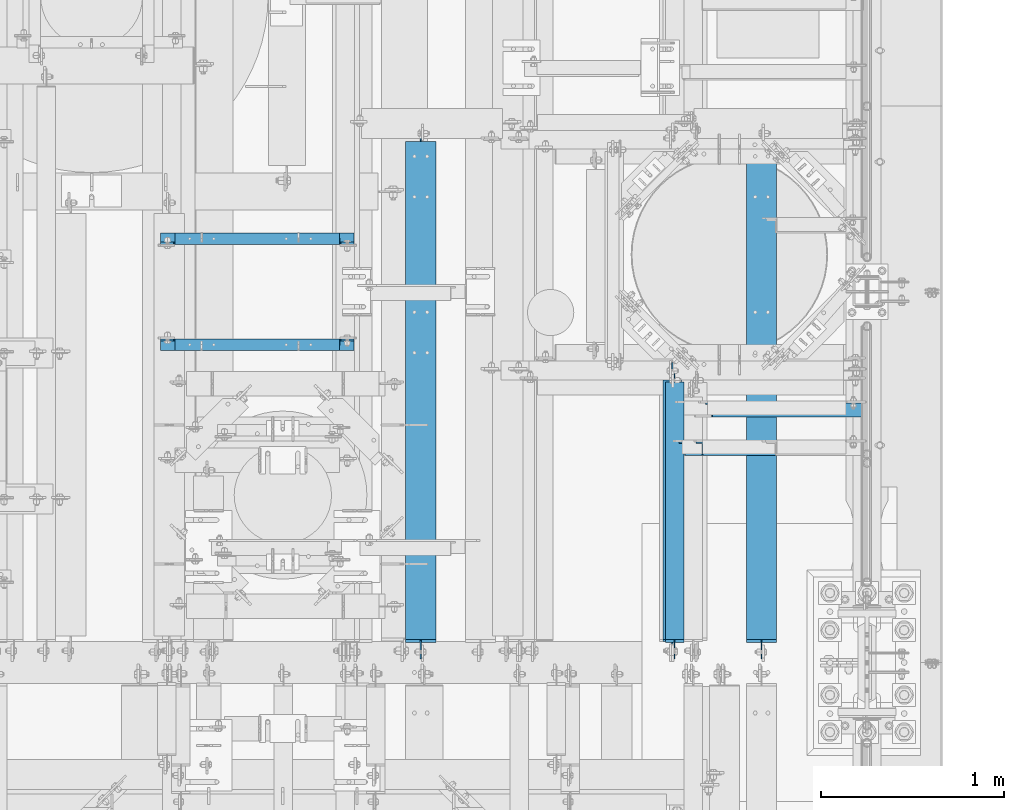
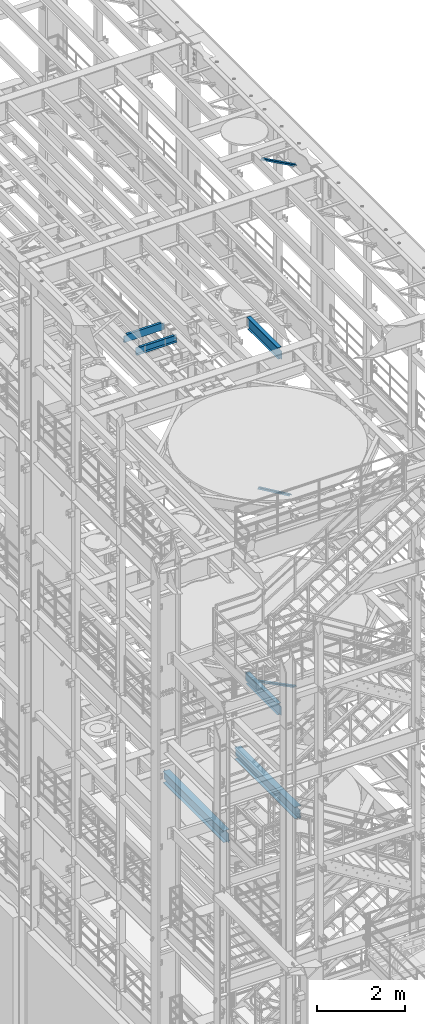
# One storey, part 1027 of 1876: 6 beams, 3 members, 9 elements without a shape of their own.
"""IFC2X3 building model written with IfcOpenShell, lengths in millimetres."""

import ifcopenshell
import ifcopenshell.guid

model = None  # the IFC model being written
_history = None  # IfcOwnerHistory: only IFC2X3 demands one
_inside = {}  # id of a spatial element -> (the spatial element, [elements in it])
_under = {}  # id of a project, library or spatial element -> (it, [spatial elements below it])
_declared = {}  # id of a project -> (the project, [libraries it declares])
_typed = {}  # id of a type object -> (the type object, [elements of that type])
_made_of = {}  # id of a material, layer set ... -> (it, [elements and type objects made of it])


def new_model(schema):
    """Start an empty IFC model of exactly this schema.

    Asked for "IFC4X3", IfcOpenShell would pick the latest addendum, in which some entities
    have other attributes; the version numbers below select the first issue.
    IFC2X3 requires an IfcOwnerHistory on every rooted entity: one is made here for all.
    """
    global model, _history
    if schema == "IFC4X3":
        model = ifcopenshell.file(schema_version=(4, 3, 0, 0))
    else:
        model = ifcopenshell.file(schema=schema)
    _inside.clear()
    _under.clear()
    _declared.clear()
    _typed.clear()
    _made_of.clear()
    _history = None
    if model.schema == "IFC2X3":
        org = make("IfcOrganization", Name="unknown")
        user = make(
            "IfcPersonAndOrganization",
            ThePerson=make("IfcPerson", FamilyName="unknown"),
            TheOrganization=org,
        )
        app = make(
            "IfcApplication",
            ApplicationDeveloper=org,
            Version="unknown",
            ApplicationFullName="unknown",
            ApplicationIdentifier="unknown",
        )
        _history = make(
            "IfcOwnerHistory",
            OwningUser=user,
            OwningApplication=app,
            ChangeAction="ADDED",
            CreationDate=0,
        )
    return model


def make(cls, **values):
    """One entity of the class cls with the attributes given. An attribute that is None is left unset."""
    return model.create_entity(
        cls, **{name: value for name, value in values.items() if value is not None}
    )


def rooted(cls, **values):
    """An entity with a GlobalId (a new one), such as an element, a storey or a relation."""
    return make(cls, GlobalId=ifcopenshell.guid.new(), OwnerHistory=_history, **values)


def si_unit(unit_type, name, prefix=None):
    """IfcSIUnit, for example si_unit("LENGTHUNIT", "METRE", prefix="MILLI")."""
    return make("IfcSIUnit", UnitType=unit_type, Prefix=prefix, Name=name)


def assignment(units):
    """IfcUnitAssignment: the units of a project."""
    return None if units is None else make("IfcUnitAssignment", Units=units)


def point(xyz):
    """IfcCartesianPoint."""
    return None if xyz is None else make("IfcCartesianPoint", Coordinates=xyz)


def direction(xyz):
    """IfcDirection."""
    return None if xyz is None else make("IfcDirection", DirectionRatios=xyz)


def frame(location, z_axis=None, x_axis=None):
    """IfcAxis2Placement3D, a coordinate frame: its origin and axes. An axis left out is left unset."""
    return make(
        "IfcAxis2Placement3D",
        Location=point(location),
        Axis=direction(z_axis),
        RefDirection=direction(x_axis),
    )


def origin_with_axes():
    """The frame at (0, 0, 0) with the z axis (0, 0, 1) and the x axis (1, 0, 0) written out."""
    return frame((0.0, 0.0, 0.0), z_axis=(0.0, 0.0, 1.0), x_axis=(1.0, 0.0, 0.0))


def place(relative_to, where):
    """IfcLocalPlacement: puts the frame where relative to a parent placement (None: the world)."""
    return make(
        "IfcLocalPlacement", PlacementRelTo=relative_to, RelativePlacement=where
    )


def context(
    kind, dimensions, precision=None, world=None, true_north=None, identifier=None
):
    """IfcGeometricRepresentationContext, for example the 3D "Model" context."""
    return make(
        "IfcGeometricRepresentationContext",
        ContextIdentifier=identifier,
        ContextType=kind,
        CoordinateSpaceDimension=dimensions,
        Precision=precision,
        WorldCoordinateSystem=world,
        TrueNorth=true_north,
    )


def subcontext(parent, identifier, kind, view, scale=None):
    """IfcGeometricRepresentationSubContext, for example "Body" below "Model"."""
    return make(
        "IfcGeometricRepresentationSubContext",
        ContextIdentifier=identifier,
        ContextType=kind,
        ParentContext=parent,
        TargetScale=scale,
        TargetView=view,
    )


def project(units=None, contexts=None):
    """IfcProject with its units and contexts."""
    return rooted(
        "IfcProject",
        Name="project",
        RepresentationContexts=contexts,
        UnitsInContext=assignment(units),
    )


def spatial(cls, under=None, at=None, **own):
    """A site, building, storey or space (cls), placed at a placement, below another one or the project."""
    s = rooted(cls, ObjectPlacement=at, **own)
    if under is not None:
        _under.setdefault(under.id(), (under, []))[1].append(s)
    return s


def faces_of(points, faces, orient=None, outer=None):
    """IfcFace entities. A face is a list of loops; a loop is a list of indices into points, from 0.

    orient and outer hold one flag for each loop. By default every Orientation is true, the
    first loop of a face is its IfcFaceOuterBound and the others are IfcFaceBound.
    """
    made = []
    for i, loops in enumerate(faces):
        bounds = []
        for j, loop in enumerate(loops):
            is_outer = j == 0 if outer is None else outer[i][j]
            bounds.append(
                make(
                    "IfcFaceOuterBound" if is_outer else "IfcFaceBound",
                    Bound=make("IfcPolyLoop", Polygon=[points[k] for k in loop]),
                    Orientation=True if orient is None else orient[i][j],
                )
            )
        made.append(make("IfcFace", Bounds=bounds))
    return made


def faceted_brep(points, faces, orient=None, outer=None, voids=None):
    """IfcFacetedBrep: a solid bounded by flat faces; with voids (closed shells), ...WithVoids."""
    shared = [point(p) for p in points]
    hull = make("IfcClosedShell", CfsFaces=faces_of(shared, faces, orient, outer))
    if voids is None:
        return make("IfcFacetedBrep", Outer=hull)
    return make(
        "IfcFacetedBrepWithVoids",
        Outer=hull,
        Voids=[
            make(cls, CfsFaces=faces_of(shared, fs, o, b)) for cls, fs, o, b in voids
        ],
    )


def shape(context_of_items, identifier, shape_type, items):
    """IfcShapeRepresentation: the items that make up one representation, for example the "Body"."""
    return make(
        "IfcShapeRepresentation",
        ContextOfItems=context_of_items,
        RepresentationIdentifier=identifier,
        RepresentationType=shape_type,
        Items=items,
    )


def material(Name=None, Category=None):
    """IfcMaterial."""
    return make("IfcMaterial", Name=Name, Category=Category)


def made_of(thing, what):
    """Note that an element or type object is made of a material, layer set ...; save() writes the relation."""
    if what is not None:
        _made_of.setdefault(what.id(), (what, []))[1].append(thing)
    return thing


def type_object(cls, material=None, **own):
    """A type object (cls), such as IfcWallType, which elements share."""
    return made_of(rooted(cls, **own), material)


def element(
    cls,
    number,
    at=None,
    inside=None,
    cuts=None,
    type_object=None,
    material=None,
    context=None,
    identifier="Body",
    shape_type=None,
    held_by="IfcProductDefinitionShape",
    body=None,
    shapes=None,
    **own,
):
    """One element of the class cls, such as IfcWall. Its Tag is "e" and its number.

    at: its placement. inside: the storey or other place that contains it. cuts: it is an
    opening in that element (IfcRelVoidsElement). A single representation is given by context,
    identifier, shape_type and body (its items); several are given by shapes. held_by: the class
    of the entity that holds the representations. save() writes the other relations.
    """
    e = rooted(cls, Tag="e%d" % number, ObjectPlacement=at, **own)
    if body is not None:
        shapes = [shape(context, identifier, shape_type, body)]
    if shapes is not None:
        e.Representation = make(held_by, Representations=shapes)
    if inside is not None:
        _inside.setdefault(inside.id(), (inside, []))[1].append(e)
    if cuts is not None:
        rooted(
            "IfcRelVoidsElement", RelatingBuildingElement=cuts, RelatedOpeningElement=e
        )
    if type_object is not None:
        _typed.setdefault(type_object.id(), (type_object, []))[1].append(e)
    return made_of(e, material)


def aggregate(whole, parts):
    """IfcRelAggregates: a whole, such as a stair, and the parts it consists of."""
    return rooted("IfcRelAggregates", RelatingObject=whole, RelatedObjects=parts)


def save(model, path):
    """Write the relations noted so far, then the file.

    IfcRelAggregates (storeys below a building ...), IfcRelContainedInSpatialStructure (elements
    in a storey), IfcRelDefinesByType, IfcRelAssociatesMaterial and IfcRelDeclares: one each for
    every whole, place, type object, material and project.
    """
    for whole, parts in _under.values():
        aggregate(whole, parts)
    for where, things in _inside.values():
        rooted(
            "IfcRelContainedInSpatialStructure",
            RelatedElements=things,
            RelatingStructure=where,
        )
    for kind, things in _typed.values():
        rooted("IfcRelDefinesByType", RelatedObjects=things, RelatingType=kind)
    for what, things in _made_of.values():
        rooted("IfcRelAssociatesMaterial", RelatedObjects=things, RelatingMaterial=what)
    for by, libraries in _declared.values():
        rooted("IfcRelDeclares", RelatingContext=by, RelatedDefinitions=libraries)
    model.write(path)


model = new_model("IFC2X3")

# Units and contexts
model_context = context("Model", 3, precision=1e-05, world=origin_with_axes())
body_context = subcontext(model_context, "Body", "Model", "MODEL_VIEW")
ifc_project = project(units=[si_unit("LENGTHUNIT", "METRE", prefix="MILLI"), si_unit("AREAUNIT", "SQUARE_METRE"), si_unit("VOLUMEUNIT", "CUBIC_METRE"), si_unit("MASSUNIT", "GRAM", prefix="KILO"), si_unit("TIMEUNIT", "SECOND"), si_unit("PLANEANGLEUNIT", "RADIAN"), si_unit("SOLIDANGLEUNIT", "STERADIAN"), si_unit("THERMODYNAMICTEMPERATUREUNIT", "DEGREE_CELSIUS"), si_unit("LUMINOUSINTENSITYUNIT", "LUMEN")], contexts=[model_context])

# Site, building, storey
site_placement = place(None, origin_with_axes())
site = spatial("IfcSite", under=ifc_project, at=site_placement, CompositionType="ELEMENT")
building_placement = place(site_placement, origin_with_axes())
building = spatial("IfcBuilding", under=site, at=building_placement, Name="Undefined", CompositionType="ELEMENT")
storey_placement = place(building_placement, origin_with_axes())
storey = spatial("IfcBuildingStorey", under=building, at=storey_placement, Name="Undefined", CompositionType="ELEMENT", Elevation=0.0)

# Assembly, member
assembly_1_placement = place(storey_placement, origin_with_axes())
assembly_1 = element("IfcElementAssembly", 1, at=assembly_1_placement, inside=storey, AssemblyPlace="NOTDEFINED", PredefinedType="RIGID_FRAME")
ifc_material_1 = material(Name="STEEL/A36")
member_type = type_object("IfcMemberType", Name="L3X3X3/8", PredefinedType="NOTDEFINED")
member_1_placement = place(assembly_1_placement, frame((6536.16116201617, 2695.575, 8132.02232402439), z_axis=(0.0, -1.0, 0.0), x_axis=(0.894427191199916, 0.0, -0.447213595099958)))
member_1 = element("IfcMember", 2, at=member_1_placement, type_object=member_type, material=ifc_material_1, ObjectType="L3X3X3/8", context=body_context, shape_type="Brep", body=[
    faceted_brep([(78.0946740306676, 38.1000000000076, -38.0999999999999), (78.0946740306676, 38.1000000000076, 38.0999999999999), (1170.5326724749, 38.0999999997912, 38.0999999999999), (1170.5326724749, 38.0999999997912, -38.0999999999999), (78.0946740306676, 28.5750000000025, 38.0999999999999), (1170.5326724749, 28.5749999997861, 38.0999999999999), (78.0946740306676, 28.5750000000025, -28.5749999999998), (1170.5326724749, 28.5749999997861, -28.5749999999998), (78.0946740306667, -38.1000000000367, -28.5749999999998), (1170.5326724749, -38.1000000002532, -28.5749999999998), (78.0946740306667, -38.1000000000367, -38.0999999999999), (1170.5326724749, -38.1000000002532, -38.0999999999999)], [[[0, 1, 2, 3]], [[1, 4, 5, 2]], [[4, 6, 7, 5]], [[6, 8, 9, 7]], [[8, 10, 11, 9]], [[10, 0, 3, 11]], [[5, 7, 9, 11, 3, 2]], [[10, 8, 6, 4, 1, 0]]]),
])
aggregate(assembly_1, [member_1])

assembly_2_placement = place(storey_placement, origin_with_axes())
assembly_2 = element("IfcElementAssembly", 3, at=assembly_2_placement, inside=storey, Name="BRACE", AssemblyPlace="NOTDEFINED", PredefinedType="RIGID_FRAME")
member_2_placement = place(assembly_2_placement, frame((6673.56288386735, 2908.3, 13302.1718727092), z_axis=(0.0, -1.0, 0.0), x_axis=(0.861630637805759, 0.0, -0.507535854885584)))
member_2 = element("IfcMember", 4, at=member_2_placement, type_object=member_type, material=ifc_material_1, Name="BRACE", ObjectType="L3X3X3/8", context=body_context, shape_type="Brep", body=[
    faceted_brep([(93.8357350541173, 38.0999999999913, -38.0999999999999), (93.8357350541173, 38.0999999999913, 38.0999999999999), (1052.95263444459, 38.0999999997257, 38.0999999999999), (1052.95263444459, 38.0999999997257, -38.0999999999999), (93.8357350541228, 28.5749999999862, 38.0999999999999), (1052.95263444459, 28.5749999997206, 38.0999999999999), (93.8357350541228, 28.5749999999862, -28.5749999999998), (1052.95263444459, 28.5749999997206, -28.5749999999998), (93.8357350541537, -38.100000000044, -28.5749999999998), (1052.95263444462, -38.100000000306, -28.5749999999998), (93.8357350541537, -38.100000000044, -38.0999999999999), (1052.95263444462, -38.100000000306, -38.0999999999999)], [[[0, 1, 2, 3]], [[1, 4, 5, 2]], [[4, 6, 7, 5]], [[6, 8, 9, 7]], [[8, 10, 11, 9]], [[10, 0, 3, 11]], [[5, 7, 9, 11, 3, 2]], [[10, 8, 6, 4, 1, 0]]]),
])
aggregate(assembly_2, [member_2])

assembly_3_placement = place(storey_placement, origin_with_axes())
assembly_3 = element("IfcElementAssembly", 5, at=assembly_3_placement, inside=storey, AssemblyPlace="NOTDEFINED", PredefinedType="RIGID_FRAME")
member_3_placement = place(assembly_3_placement, frame((6649.22451200435, 2695.575, 22521.7692276093), z_axis=(0.0, -1.0, 0.0), x_axis=(0.877448093107094, 0.0, -0.479671600058544)))
member_3 = element("IfcMember", 6, at=member_3_placement, type_object=member_type, material=ifc_material_1, ObjectType="L3X3X3/8", context=body_context, shape_type="Brep", body=[
    faceted_brep([(59.7482362440578, 38.0999999998749, -38.0999999999999), (59.7482362440578, 38.0999999998749, 38.0999999999999), (1062.91900040893, 38.0999999984488, 38.0999999999999), (1062.91900040893, 38.0999999984488, -38.0999999999999), (59.7482362440696, 28.5749999998843, 38.0999999999999), (1062.91900040895, 28.5749999984582, 38.0999999999999), (59.7482362440696, 28.5749999998843, -28.5749999999998), (1062.91900040895, 28.5749999984582, -28.5749999999998), (59.7482362441442, -38.1000000000495, -28.5749999999998), (1062.91900040902, -38.1000000014719, -28.5749999999998), (59.7482362441442, -38.1000000000495, -38.0999999999999), (1062.91900040902, -38.1000000014719, -38.0999999999999)], [[[0, 1, 2, 3]], [[1, 4, 5, 2]], [[4, 6, 7, 5]], [[6, 8, 9, 7]], [[8, 10, 11, 9]], [[10, 0, 3, 11]], [[5, 7, 9, 11, 3, 2]], [[10, 8, 6, 4, 1, 0]]]),
])
aggregate(assembly_3, [member_3])

# Assembly, beam
assembly_4_placement = place(storey_placement, origin_with_axes())
assembly_4 = element("IfcElementAssembly", 7, at=assembly_4_placement, inside=storey, Name="BEAM", AssemblyPlace="NOTDEFINED", PredefinedType="RIGID_FRAME")
ifc_material_2 = material(Name="STEEL/A992")
beam_type_1 = type_object("IfcBeamType", Name="W12X26", PredefinedType="NOTDEFINED")
beam_1_placement = place(assembly_4_placement, frame((7042.14884554985, 1524.0, 4975.225), z_axis=(0.0, 0.0, 1.0), x_axis=(0.0, 1.0, 0.0)))
beam_1 = element("IfcBeam", 8, at=beam_1_placement, type_object=beam_type_1, material=ifc_material_2, Name="BEAM", ObjectType="W12X26", context=body_context, shape_type="Brep", body=[
    faceted_brep([(19.8437512414296, -3.17500000000109, -130.175), (19.8437487585795, 3.17499999999927, -130.175), (96.0437824675421, 3.175000000002, -130.175), (96.0437824675423, -3.17499999999745, -130.175), (100.903861985588, 3.175000000002, -131.141729922588), (100.903861985589, -3.17499999999745, -131.141729922588), (105.024038453743, 3.17500000000291, -133.894743823066), (105.024038453744, -3.17499999999654, -133.894743823066), (107.777052354222, 3.17500000000291, -138.01492029122), (107.777052354222, -3.17499999999745, -138.01492029122), (108.743782276811, -3.17499999999654, -142.874999809265), (108.74378227681, 3.17500000000291, -142.874999809265), (108.74375, 3.17500009516311, -146.049999999999), (108.743782276807, 82.5500000000084, -146.05), (108.743782276807, 82.5500000000084, -155.575), (108.743782276814, -82.5500000000029, -155.575), (108.743782276814, -82.5500000000029, -146.05), (108.74375, -3.17499999999995, -146.049999999999), (2854.32496772472, -82.5499999998874, 155.575), (2854.32496772472, 82.5500000001248, 155.575), (127.793782276814, 82.5500000000102, 155.575), (127.793782276821, -82.5500000000029, 155.575), (2854.95651445322, -82.5499999998874, 146.05), (2854.32496772472, -82.5499999998874, 149.224999809265), (127.793782276821, -82.5500000000029, 146.05), (2854.32496772472, 82.5500000001248, 149.224999809265), (2854.95651445321, 82.5500000001257, 146.05), (127.793782276814, 82.5500000000102, 146.05), (2854.95651445321, 3.17500000011933, 146.05), (127.79375, 3.17500000000018, 146.05), (115.09378246755, -3.17499999999654, 117.474999999999), (115.093782467549, 3.17500000000382, 117.474999999999), (19.8437487585795, 3.17499999999927, 117.474999999999), (19.8437512414296, -3.17500000000109, 117.474999999999), (119.953861985596, -3.17499999999654, 118.441729922587), (119.953861985596, 3.17500000000382, 118.441729922587), (124.074038453751, -3.17499999999654, 121.194743823065), (124.074038453751, 3.17500000000382, 121.194743823065), (126.82705235423, -3.17499999999654, 125.314920291219), (126.827052354229, 3.17500000000473, 125.314920291219), (127.793782276818, -3.17499999999654, 130.174999809265), (127.793782276817, 3.17500000000382, 130.174999809265), (127.79375, -3.17500000000018, 146.05), (2854.95651445321, -3.17499999988104, 146.05), (2855.29169764731, -3.17499999988104, 144.364920291219), (2855.29169764731, 3.17500000011933, 144.364920291219), (2858.04471154779, -3.17499999988104, 140.244743823066), (2858.04471154779, 3.17500000011933, 140.244743823066), (2862.16488801594, -3.17499999988104, 137.491729922587), (2862.16488801594, 3.17500000011933, 137.491729922587), (2867.02496753399, -3.17499999988104, 136.525), (2867.02496753399, 3.17500000011933, 136.525), (2936.8750012421, -3.1749999998774, 136.525), (2936.87499875925, 3.17500000012296, 136.525), (2936.8750012421, -3.1749999998774, -130.175), (2936.87499875925, 3.17500000012296, -130.175), (2860.67496753399, -3.17499999988013, -130.175), (2860.67496753399, 3.17500000011933, -130.175), (2855.81488801594, -3.17499999988013, -131.141729922588), (2855.81488801594, 3.17500000011933, -131.141729922588), (2851.69471154779, -3.17499999988104, -133.894743823066), (2851.69471154779, 3.17500000011933, -133.894743823066), (2848.94169764731, -3.17499999988104, -138.01492029122), (2848.94169764731, 3.17500000011933, -138.01492029122), (2847.97496772472, -3.17499999988104, -142.874999809265), (2847.97496772472, 3.17500000011842, -142.874999809265), (2847.97496772472, -3.17499999988104, -146.05), (2847.97496772472, -82.5499999998874, -146.05), (2847.97496772472, -82.5499999998874, -155.575), (2847.97496772471, 82.5500000001239, -155.575), (2847.97496772471, 82.5500000001239, -146.05), (2847.97496772472, 3.17500000011842, -146.05)], [[[0, 1, 2, 3]], [[3, 2, 4, 5]], [[5, 4, 6, 7]], [[7, 6, 8, 9]], [[10, 11, 12, 13, 14, 15, 16, 17]], [[9, 8, 11, 10]], [[18, 19, 20, 21]], [[22, 23, 18, 21, 24]], [[18, 23, 25, 19]], [[19, 25, 26, 27, 20]], [[26, 28, 29, 27]], [[30, 31, 32, 33]], [[34, 35, 31, 30]], [[36, 37, 35, 34]], [[38, 39, 37, 36]], [[40, 41, 39, 38]], [[21, 20, 27, 29, 41, 40, 42, 24]], [[43, 22, 24, 42]], [[44, 45, 28, 26, 25, 23, 22, 43]], [[46, 47, 45, 44]], [[48, 49, 47, 46]], [[50, 51, 49, 48]], [[52, 53, 51, 50]], [[53, 52, 54, 55]], [[54, 56, 57, 55]], [[58, 59, 57, 56]], [[60, 61, 59, 58]], [[62, 63, 61, 60]], [[64, 65, 63, 62]], [[66, 67, 68, 69, 70, 71, 65, 64]], [[67, 66, 17, 16]], [[68, 67, 16, 15]], [[69, 68, 15, 14]], [[70, 69, 14, 13]], [[71, 70, 13, 12]], [[6, 4, 2, 1, 32, 31, 35, 37, 39, 41, 29, 28, 45, 47, 49, 51, 53, 55, 57, 59, 61, 63, 65, 71, 12, 11, 8]], [[33, 32, 1, 0]], [[66, 64, 62, 60, 58, 56, 54, 52, 50, 48, 46, 44, 43, 42, 40, 38, 36, 34, 30, 33, 0, 3, 5, 7, 9, 10, 17]]]),
])
aggregate(assembly_4, [beam_1])

assembly_5_placement = place(storey_placement, origin_with_axes())
assembly_5 = element("IfcElementAssembly", 9, at=assembly_5_placement, inside=storey, Name="BEAM", AssemblyPlace="NOTDEFINED", PredefinedType="RIGID_FRAME")
beam_2_placement = place(assembly_5_placement, frame((5175.24884554985, 1524.0, 4975.225), z_axis=(0.0, 0.0, 1.0), x_axis=(0.0, 1.0, 0.0)))
beam_2 = element("IfcBeam", 10, at=beam_2_placement, type_object=beam_type_1, material=ifc_material_2, Name="BEAM", ObjectType="W12X26", context=body_context, shape_type="Brep", body=[
    faceted_brep([(19.8437512414296, -3.17500000000109, -130.175), (19.8437487585795, 3.17499999999927, -130.175), (96.0437824675421, 3.175000000002, -130.175), (96.0437824675423, -3.17499999999745, -130.175), (100.903861985588, 3.175000000002, -131.141729922588), (100.903861985589, -3.17499999999745, -131.141729922588), (105.024038453743, 3.17500000000291, -133.894743823066), (105.024038453744, -3.17499999999654, -133.894743823066), (107.777052354222, 3.17500000000291, -138.01492029122), (107.777052354222, -3.17499999999745, -138.01492029122), (108.743782276811, -3.17499999999654, -142.874999809265), (108.74378227681, 3.17500000000291, -142.874999809265), (108.74375, 3.17500009516311, -146.049999999999), (108.743782276807, 82.5500000000084, -146.05), (108.743782276807, 82.5500000000084, -155.575), (108.743782276814, -82.5500000000029, -155.575), (108.743782276814, -82.5500000000029, -146.05), (108.74375, -3.17499999999995, -146.049999999999), (2854.32496772472, -82.5499999998874, 155.575), (2854.32496772472, 82.5500000001248, 155.575), (127.793782276814, 82.5500000000102, 155.575), (127.793782276821, -82.5500000000029, 155.575), (2854.95651445322, -82.5499999998874, 146.05), (2854.32496772472, -82.5499999998874, 149.224999809265), (127.793782276821, -82.5500000000029, 146.05), (2854.32496772472, 82.5500000001248, 149.224999809265), (2854.95651445321, 82.5500000001257, 146.05), (127.793782276814, 82.5500000000102, 146.05), (2854.95651445321, 3.17500000011933, 146.05), (127.79375, 3.17500000000018, 146.05), (115.09378246755, -3.17499999999654, 117.474999999999), (115.093782467549, 3.17500000000382, 117.474999999999), (19.8437487585795, 3.17499999999927, 117.474999999999), (19.8437512414296, -3.17500000000109, 117.474999999999), (119.953861985596, -3.17499999999654, 118.441729922587), (119.953861985596, 3.17500000000382, 118.441729922587), (124.074038453751, -3.17499999999654, 121.194743823065), (124.074038453751, 3.17500000000382, 121.194743823065), (126.82705235423, -3.17499999999654, 125.314920291219), (126.827052354229, 3.17500000000473, 125.314920291219), (127.793782276818, -3.17499999999654, 130.174999809265), (127.793782276817, 3.17500000000382, 130.174999809265), (127.79375, -3.17500000000018, 146.05), (2854.95651445321, -3.17499999988104, 146.05), (2855.29169764731, -3.17499999988104, 144.364920291219), (2855.29169764731, 3.17500000011933, 144.364920291219), (2858.04471154779, -3.17499999988104, 140.244743823066), (2858.04471154779, 3.17500000011933, 140.244743823066), (2862.16488801594, -3.17499999988104, 137.491729922587), (2862.16488801594, 3.17500000011933, 137.491729922587), (2867.02496753399, -3.17499999988104, 136.525), (2867.02496753399, 3.17500000011933, 136.525), (2936.8750012421, -3.1749999998774, 136.525), (2936.87499875925, 3.17500000012296, 136.525), (2936.8750012421, -3.1749999998774, -130.175), (2936.87499875925, 3.17500000012296, -130.175), (2860.67496753399, -3.17499999988013, -130.175), (2860.67496753399, 3.17500000011933, -130.175), (2855.81488801594, -3.17499999988013, -131.141729922588), (2855.81488801594, 3.17500000011933, -131.141729922588), (2851.69471154779, -3.17499999988104, -133.894743823066), (2851.69471154779, 3.17500000011933, -133.894743823066), (2848.94169764731, -3.17499999988104, -138.01492029122), (2848.94169764731, 3.17500000011933, -138.01492029122), (2847.97496772472, -3.17499999988104, -142.874999809265), (2847.97496772472, 3.17500000011842, -142.874999809265), (2847.97496772472, -3.17499999988104, -146.05), (2847.97496772472, -82.5499999998874, -146.05), (2847.97496772472, -82.5499999998874, -155.575), (2847.97496772471, 82.5500000001239, -155.575), (2847.97496772471, 82.5500000001239, -146.05), (2847.97496772472, 3.17500000011842, -146.05)], [[[0, 1, 2, 3]], [[3, 2, 4, 5]], [[5, 4, 6, 7]], [[7, 6, 8, 9]], [[10, 11, 12, 13, 14, 15, 16, 17]], [[9, 8, 11, 10]], [[18, 19, 20, 21]], [[22, 23, 18, 21, 24]], [[18, 23, 25, 19]], [[19, 25, 26, 27, 20]], [[26, 28, 29, 27]], [[30, 31, 32, 33]], [[34, 35, 31, 30]], [[36, 37, 35, 34]], [[38, 39, 37, 36]], [[40, 41, 39, 38]], [[21, 20, 27, 29, 41, 40, 42, 24]], [[43, 22, 24, 42]], [[44, 45, 28, 26, 25, 23, 22, 43]], [[46, 47, 45, 44]], [[48, 49, 47, 46]], [[50, 51, 49, 48]], [[52, 53, 51, 50]], [[53, 52, 54, 55]], [[54, 56, 57, 55]], [[58, 59, 57, 56]], [[60, 61, 59, 58]], [[62, 63, 61, 60]], [[64, 65, 63, 62]], [[66, 67, 68, 69, 70, 71, 65, 64]], [[67, 66, 17, 16]], [[68, 67, 16, 15]], [[69, 68, 15, 14]], [[70, 69, 14, 13]], [[71, 70, 13, 12]], [[6, 4, 2, 1, 32, 31, 35, 37, 39, 41, 29, 28, 45, 47, 49, 51, 53, 55, 57, 59, 61, 63, 65, 71, 12, 11, 8]], [[33, 32, 1, 0]], [[66, 64, 62, 60, 58, 56, 54, 52, 50, 48, 46, 44, 43, 42, 40, 38, 36, 34, 30, 33, 0, 3, 5, 7, 9, 10, 17]]]),
])
aggregate(assembly_5, [beam_2])

assembly_6_placement = place(storey_placement, origin_with_axes())
assembly_6 = element("IfcElementAssembly", 11, at=assembly_6_placement, inside=storey, Name="BEAM", AssemblyPlace="NOTDEFINED", PredefinedType="RIGID_FRAME")
beam_type_2 = type_object("IfcBeamType", Name="W12X16", PredefinedType="NOTDEFINED")
beam_3_placement = place(assembly_6_placement, frame((6565.9, 1524.0, 17830.8), z_axis=(0.0, 0.0, 1.0), x_axis=(0.0, 1.0, 0.0)))
beam_3 = element("IfcBeam", 12, at=beam_3_placement, type_object=beam_type_2, material=ifc_material_2, Name="BEAM", ObjectType="W12X16", context=body_context, shape_type="Brep", body=[
    faceted_brep([(1495.425, -3.17500000000018, -146.049999999999), (1495.425, -50.8000000000002, -146.049999999999), (1495.425, -50.8000000000002, -152.400000000001), (1495.425, 50.8000000000002, -152.400000000001), (1495.425, 50.8000000000002, -146.049999999999), (1495.425, 3.17500000569635, -146.049999999999), (1495.425, 3.17500003558052, -139.699999809261), (1495.425, -3.17500000000018, -139.699999809261), (1496.39172992259, 3.17500003480291, -134.839920291215), (1496.39172992259, -3.17500000000018, -134.839920291215), (1499.14474382307, 3.17500003413898, -130.719743823061), (1499.14474382307, -3.17500000000018, -130.719743823061), (1503.26492029122, 3.17500003369059, -127.966729922584), (1503.26492029122, -3.17500000000018, -127.966729922584), (1508.12499980927, 3.17500003352598, -126.999999999996), (1508.12499980927, -3.17500000000018, -126.999999999996), (1584.325, -3.17500000000018, -126.999999999996), (1584.325, 3.17500000000018, -126.999999999996), (126.20625, 3.17499999999995, 146.049999999999), (126.20625, 50.8, 146.049999999999), (1536.7, 50.8000000000002, 146.049999999999), (1536.7, 3.17500000000018, 146.049999999999), (108.74375, -3.17499999999995, -139.699999809261), (108.74375, 3.17500002570978, -139.699999809261), (108.74375, 3.17500009516311, -146.049999999999), (108.74375, 50.8, -146.049999999999), (108.74375, 50.8, -152.400000000001), (108.74375, -50.8, -152.400000000001), (108.74375, -50.8, -146.049999999999), (108.74375, -3.17499999999995, -146.049999999999), (107.777020077412, -3.17499999999995, -134.839920291215), (107.777020077412, 3.17500002492102, -134.839920291215), (105.024006176934, -3.17499999999995, -130.719743823061), (105.024006176934, 3.17500002425209, -130.719743823061), (100.90382970878, -3.17499999999995, -127.966729922584), (100.90382970878, 3.17500002380461, -127.966729922584), (96.0437501907345, -3.17499999999995, -126.999999999996), (96.0437501907345, 3.17500002364682, -126.999999999996), (19.84375, -3.17499999999995, -126.999999999996), (19.84375, 3.17499999999995, -126.999999999996), (19.84375, -3.17499999999995, 107.950000000004), (19.84375, 3.17499999999995, 107.950000000004), (113.506250190735, -3.17499999999995, 107.950000000004), (113.506250190735, 3.17499998606149, 107.950000000004), (118.366329708781, -3.17499999999995, 108.916729922592), (118.366329708781, 3.17499998590552, 108.916729922592), (122.486506176934, -3.17499999999995, 111.669743823069), (122.486506176934, 3.17499998546009, 111.669743823069), (125.239520077413, -3.17499999999995, 115.789920291223), (125.239520077413, 3.17499998479298, 115.789920291223), (126.20625, -3.17499999999995, 120.64999980927), (126.20625, 3.17499998400558, 120.64999980927), (126.20625, -50.8, 152.400000000001), (126.20625, 50.8, 152.400000000001), (126.20625, -3.17499999999995, 146.049999999999), (126.20625, -50.8, 146.049999999999), (1536.7, -3.17500000000018, 146.049999999999), (1536.7, -50.8000000000002, 146.049999999999), (1536.7, -50.8000000000002, 152.400000000001), (1536.7, 50.8000000000002, 152.400000000001), (1536.7, -3.17500000000018, 139.699999809269), (1536.7, 3.17499999089159, 139.699999809269), (1537.66672992259, -3.17500000000018, 134.839920291222), (1537.66672992259, 3.17499999166284, 134.839920291222), (1540.41974382307, -3.17500000000018, 130.719743823069), (1540.41974382307, 3.17499999231313, 130.719743823069), (1544.53992029122, -3.17500000000018, 127.966729922591), (1544.53992029122, 3.17499999274332, 127.966729922591), (1549.39999980926, -3.17500000000018, 127.000000000004), (1549.39999980926, 3.17499999288884, 127.000000000004), (1584.325, -3.17500000000018, 127.000000000004), (1584.325, 3.17500000000018, 127.000000000004)], [[[0, 1, 2, 3, 4, 5, 6, 7]], [[7, 6, 8, 9]], [[9, 8, 10, 11]], [[11, 10, 12, 13]], [[13, 12, 14, 15]], [[16, 15, 14, 17]], [[18, 19, 20, 21]], [[22, 23, 24, 25, 26, 27, 28, 29]], [[30, 31, 23, 22]], [[32, 33, 31, 30]], [[34, 35, 33, 32]], [[36, 37, 35, 34]], [[38, 39, 37, 36]], [[40, 41, 39, 38]], [[42, 43, 41, 40]], [[44, 45, 43, 42]], [[46, 47, 45, 44]], [[48, 49, 47, 46]], [[50, 51, 49, 48]], [[52, 53, 19, 18, 51, 50, 54, 55]], [[55, 54, 56, 57]], [[52, 55, 57, 58]], [[53, 52, 58, 59]], [[19, 53, 59, 20]], [[58, 57, 56, 60, 61, 21, 20, 59]], [[62, 63, 61, 60]], [[64, 65, 63, 62]], [[66, 67, 65, 64]], [[68, 69, 67, 66]], [[70, 71, 69, 68]], [[71, 70, 16, 17]], [[12, 10, 8, 6, 5, 24, 23, 31, 33, 35, 37, 39, 41, 43, 45, 47, 49, 51, 18, 21, 61, 63, 65, 67, 69, 71, 17, 14]], [[25, 24, 5, 4]], [[26, 25, 4, 3]], [[27, 26, 3, 2]], [[28, 27, 2, 1]], [[29, 28, 1, 0]], [[70, 68, 66, 64, 62, 60, 56, 54, 50, 48, 46, 44, 42, 40, 38, 36, 34, 32, 30, 22, 29, 0, 7, 9, 11, 13, 15, 16]]]),
])
aggregate(assembly_6, [beam_3])

assembly_7_placement = place(storey_placement, origin_with_axes())
assembly_7 = element("IfcElementAssembly", 13, at=assembly_7_placement, inside=storey, Name="BEAM", AssemblyPlace="NOTDEFINED", PredefinedType="RIGID_FRAME")
beam_4_placement = place(assembly_7_placement, frame((6553.2, 1524.0, 8001.0), z_axis=(0.0, 0.0, 1.0), x_axis=(0.0, 1.0, 0.0)))
beam_4 = element("IfcBeam", 14, at=beam_4_placement, type_object=beam_type_2, material=ifc_material_2, Name="BEAM", ObjectType="W12X16", context=body_context, shape_type="Brep", body=[
    faceted_brep([(1547.8125, -3.17500000000018, -146.05), (1547.8125, -50.8000000000002, -146.05), (1547.8125, -50.8000000000002, -152.4), (1547.8125, 50.8000000000002, -152.4), (1547.8125, 50.8000000000002, -146.05), (1547.8125, 3.17500000000018, -146.05), (1547.8125, 3.17500000000018, -139.699999809264), (1547.8125, -3.17500000000018, -139.699999809264), (1548.77922992259, 3.17500000000018, -134.839920291219), (1548.77922992259, -3.17500000000018, -134.839920291219), (1551.53224382307, 3.17500000000018, -130.719743823065), (1551.53224382307, -3.17500000000018, -130.719743823065), (1555.65242029122, 3.17500000000018, -127.966729922587), (1555.65242029122, -3.17500000000018, -127.966729922587), (1560.51249980927, 3.17500000000018, -126.999999999999), (1560.51249980927, -3.17500000000018, -126.999999999999), (1643.0625, -3.17500000000018, -126.999999999999), (1643.0625, 3.17500000000018, -126.999999999999), (127.79375, 3.17500000000018, 146.05), (127.79375, 50.8000000000002, 146.05), (1547.8125, 50.8000000000002, 146.05), (1547.8125, 3.17500000000018, 146.05), (115.09375, -3.17500000000018, -139.699999809266), (115.09375, 3.17500000000018, -139.699999809266), (115.09375, 3.17500000000018, -146.05), (115.09375, 50.8000000000002, -146.05), (115.09375, 50.8000000000002, -152.4), (115.09375, -50.8000000000002, -152.4), (115.09375, -50.8000000000002, -146.05), (115.09375, -3.17500000000018, -146.05), (114.127020077412, -3.17500000000018, -134.839920291221), (114.127020077412, 3.17500000000018, -134.839920291221), (111.374006176934, -3.17500000000018, -130.719743823067), (111.374006176934, 3.17500000000018, -130.719743823067), (107.25382970878, -3.17500000000018, -127.966729922588), (107.25382970878, 3.17500000000018, -127.966729922588), (102.393750190735, -3.17500000000018, -127.000000000001), (102.393750190735, 3.17500000000018, -127.000000000001), (19.84375, -3.17499999999995, -126.999999999996), (19.84375, 3.17499999999995, -126.999999999996), (19.84375, -3.17500000000018, 114.299999999999), (19.84375, 3.17500000000018, 114.299999999999), (115.093750190735, -3.17500000000018, 114.299999999999), (115.093750190735, 3.17500000000018, 114.299999999999), (119.95382970878, -3.17500000000018, 115.266729922587), (119.95382970878, 3.17500000000018, 115.266729922587), (124.074006176934, -3.17500000000018, 118.019743823065), (124.074006176934, 3.17500000000018, 118.019743823065), (126.827020077412, -3.17500000000018, 122.139920291219), (126.827020077412, 3.17500000000018, 122.139920291219), (127.79375, -3.17500000000018, 126.999999809264), (127.79375, 3.17500000000018, 126.999999809264), (127.79375, -50.8000000000002, 152.4), (127.79375, 50.8000000000002, 152.4), (127.79375, -3.17500000000018, 146.05), (127.79375, -50.8000000000002, 146.05), (1547.8125, -3.17500000000018, 146.05), (1547.8125, -50.8000000000002, 146.05), (1547.8125, -50.8000000000002, 152.4), (1547.8125, 50.8000000000002, 152.4), (1547.8125, -3.17500000000018, 139.699999809266), (1547.8125, 3.17500000000018, 139.699999809266), (1548.77922992259, -3.17500000000018, 134.839920291221), (1548.77922992259, 3.17500000000018, 134.839920291221), (1551.53224382307, -3.17500000000018, 130.719743823067), (1551.53224382307, 3.17500000000018, 130.719743823067), (1555.65242029122, -3.17500000000018, 127.966729922588), (1555.65242029122, 3.17500000000018, 127.966729922588), (1560.51249980927, -3.17500000000018, 127.000000000001), (1560.51249980927, 3.17500000000018, 127.000000000001), (1643.0625, -3.17500000000018, 127.000000000001), (1643.0625, 3.17500000000018, 127.000000000001)], [[[0, 1, 2, 3, 4, 5, 6, 7]], [[7, 6, 8, 9]], [[9, 8, 10, 11]], [[11, 10, 12, 13]], [[13, 12, 14, 15]], [[16, 15, 14, 17]], [[18, 19, 20, 21]], [[22, 23, 24, 25, 26, 27, 28, 29]], [[30, 31, 23, 22]], [[32, 33, 31, 30]], [[34, 35, 33, 32]], [[36, 37, 35, 34]], [[38, 39, 37, 36]], [[40, 41, 39, 38]], [[42, 43, 41, 40]], [[44, 45, 43, 42]], [[46, 47, 45, 44]], [[48, 49, 47, 46]], [[50, 51, 49, 48]], [[52, 53, 19, 18, 51, 50, 54, 55]], [[55, 54, 56, 57]], [[52, 55, 57, 58]], [[53, 52, 58, 59]], [[19, 53, 59, 20]], [[58, 57, 56, 60, 61, 21, 20, 59]], [[62, 63, 61, 60]], [[64, 65, 63, 62]], [[66, 67, 65, 64]], [[68, 69, 67, 66]], [[70, 71, 69, 68]], [[71, 70, 16, 17]], [[12, 10, 8, 6, 5, 24, 23, 31, 33, 35, 37, 39, 41, 43, 45, 47, 49, 51, 18, 21, 61, 63, 65, 67, 69, 71, 17, 14]], [[25, 24, 5, 4]], [[26, 25, 4, 3]], [[27, 26, 3, 2]], [[28, 27, 2, 1]], [[29, 28, 1, 0]], [[70, 68, 66, 64, 62, 60, 56, 54, 50, 48, 46, 44, 42, 40, 38, 36, 34, 32, 30, 22, 29, 0, 7, 9, 11, 13, 15, 16]]]),
])
aggregate(assembly_7, [beam_4])

assembly_8_placement = place(storey_placement, origin_with_axes())
assembly_8 = element("IfcElementAssembly", 15, at=assembly_8_placement, inside=storey, Name="BEAM", AssemblyPlace="NOTDEFINED", PredefinedType="RIGID_FRAME")
beam_type_3 = type_object("IfcBeamType", Name="C8X18.75", PredefinedType="NOTDEFINED")
beam_5_placement = place(assembly_8_placement, frame((4826.0, 3265.685937, 17881.6), z_axis=(0.0, 0.0, -1.0), x_axis=(-1.0, 0.0, 0.0)))
beam_5 = element("IfcBeam", 16, at=beam_5_placement, type_object=beam_type_3, material=ifc_material_1, Name="BEAM", ObjectType="C8X18.75", context=body_context, shape_type="Brep", body=[
    faceted_brep([(15.8749999999991, 19.0500000000002, -82.5499999999993), (15.8749999999991, 31.75, -82.5499999999993), (82.550000190734, 31.75, -82.5499999999993), (82.550000190734, 19.0500000000002, -82.5499999999993), (87.4100797087794, 31.75, -83.5167299225868), (87.4100797087794, 19.0500000000002, -83.5167299225868), (91.5302561769331, 31.75, -86.2697438230643), (91.5302561769331, 19.0500000000002, -86.2697438230643), (93.2885857534866, 19.0500000000002, -88.9012699999985), (94.2832700774115, 31.75, -90.389920291218), (94.2832700774115, 10.1145240623118, -90.389920291218), (95.2499999999991, -19.0576219043483, -95.2499998092644), (95.2499999999991, 31.75, -95.2499998092644), (95.2499999999991, 31.75, -101.599999999999), (95.2499999999991, -31.75, -101.599999999999), (95.2499999999991, -31.75, -97.3645499999984), (15.8749999999991, 31.75, 101.599999999999), (15.8749999999991, -31.75, 101.599999999999), (1076.325, -31.75, 101.599999999999), (1076.325, 31.75, 101.599999999999), (15.8749999999991, -31.75, 97.3645499999984), (1076.325, -31.75, 97.3645499999984), (15.8749999999991, 19.0500000000002, 88.9012699999985), (1076.325, 19.0500000000002, 88.9012699999985), (1076.325, 19.0500000000002, -82.5499999999993), (1076.325, 31.75, -82.5499999999993), (1009.64999980927, 19.0500000000002, -82.5499999999993), (1009.64999980927, 31.75, -82.5499999999993), (1004.78992029122, 19.0500000000002, -83.5167299225868), (1004.78992029122, 31.75, -83.5167299225868), (1000.66974382307, 19.0500000000002, -86.2697438230643), (1000.66974382307, 31.75, -86.2697438230643), (998.911414246513, 19.0500000000002, -88.9012699999985), (997.916729922588, 10.1145240623118, -90.389920291218), (997.916729922588, 31.75, -90.389920291218), (996.95, -19.0576219043483, -95.2499998092644), (996.95, 31.75, -95.2499998092644), (996.95, -31.75, -97.3645499999984), (996.95, -31.75, -101.599999999999), (996.95, 31.75, -101.599999999999)], [[[0, 1, 2, 3]], [[3, 2, 4, 5]], [[5, 4, 6, 7]], [[8, 7, 6, 9, 10]], [[11, 12, 13, 14, 15]], [[10, 9, 12, 11]], [[16, 17, 18, 19]], [[17, 20, 21, 18]], [[20, 22, 23, 21]], [[19, 18, 21, 23, 24, 25]], [[24, 26, 27, 25]], [[28, 29, 27, 26]], [[30, 31, 29, 28]], [[32, 33, 34, 31, 30]], [[35, 36, 34, 33]], [[37, 38, 39, 36, 35]], [[38, 37, 15, 14]], [[39, 38, 14, 13]], [[6, 4, 2, 1, 16, 19, 25, 27, 29, 31, 34, 36, 39, 13, 12, 9]], [[22, 20, 17, 16, 1, 0]], [[32, 30, 28, 26, 24, 23, 22, 0, 3, 5, 7, 8]], [[37, 35, 33, 32, 8, 10, 11, 15]]]),
])
aggregate(assembly_8, [beam_5])

assembly_9_placement = place(storey_placement, origin_with_axes())
assembly_9 = element("IfcElementAssembly", 17, at=assembly_9_placement, inside=storey, Name="BEAM", AssemblyPlace="NOTDEFINED", PredefinedType="RIGID_FRAME")
beam_6_placement = place(assembly_9_placement, frame((3557.5875, 3846.314063, 17881.6), z_axis=(0.0, 0.0, -1.0), x_axis=(1.0, 0.0, 0.0)))
beam_6 = element("IfcBeam", 18, at=beam_6_placement, type_object=beam_type_3, material=ifc_material_1, Name="BEAM", ObjectType="C8X18.75", context=body_context, shape_type="Brep", body=[
    faceted_brep([(1173.1625, -31.75, -97.3645499999984), (1173.1625, -31.75, -101.599999999999), (1173.1625, 31.75, -101.599999999999), (1173.1625, 31.75, -95.2499998092644), (1173.1625, -19.0576219043483, -95.2499998092644), (1174.12922992259, 31.75, -90.389920291218), (1174.12922992259, 10.1145240623118, -90.389920291218), (1175.12391424651, 19.0500000000002, -88.9012699999985), (1176.88224382307, 31.75, -86.2697438230643), (1176.88224382307, 19.0500000000002, -86.2697438230643), (1181.00242029122, 31.75, -83.5167299225868), (1181.00242029122, 19.0500000000002, -83.5167299225868), (1185.86249980927, 31.75, -82.5499999999993), (1185.86249980927, 19.0500000000002, -82.5499999999993), (1252.5375, 19.0500000000002, -82.5499999999993), (1252.5375, 31.75, -82.5499999999993), (192.0875, -31.75, 101.599999999999), (192.0875, -31.75, 97.3645499999984), (1252.5375, -31.75, 97.3645499999984), (1252.5375, -31.75, 101.599999999999), (192.0875, 31.75, 101.599999999999), (1252.5375, 31.75, 101.599999999999), (271.4625, -19.0576219043483, -95.2499998092644), (271.4625, 31.75, -95.2499998092644), (271.4625, 31.75, -101.599999999999), (271.4625, -31.75, -101.599999999999), (271.4625, -31.75, -97.3645499999984), (270.495770077412, 10.1145240623118, -90.389920291218), (270.495770077412, 31.75, -90.389920291218), (269.501085753488, 19.0500000000002, -88.9012699999985), (267.742756176934, 19.0500000000002, -86.2697438230643), (267.742756176934, 31.75, -86.2697438230643), (263.62257970878, 19.0500000000002, -83.5167299225868), (263.62257970878, 31.75, -83.5167299225868), (258.762500190735, 19.0500000000002, -82.5499999999993), (258.762500190735, 31.75, -82.5499999999993), (192.0875, 19.0500000000002, -82.5499999999993), (192.0875, 31.75, -82.5499999999993), (192.0875, 19.0500000000002, 88.9012699999985), (1252.5375, 19.0500000000002, 88.9012699999985)], [[[0, 1, 2, 3, 4]], [[4, 3, 5, 6]], [[7, 6, 5, 8, 9]], [[9, 8, 10, 11]], [[11, 10, 12, 13]], [[14, 13, 12, 15]], [[16, 17, 18, 19]], [[20, 16, 19, 21]], [[22, 23, 24, 25, 26]], [[27, 28, 23, 22]], [[29, 30, 31, 28, 27]], [[32, 33, 31, 30]], [[34, 35, 33, 32]], [[36, 37, 35, 34]], [[38, 17, 16, 20, 37, 36]], [[17, 38, 39, 18]], [[21, 19, 18, 39, 14, 15]], [[10, 8, 5, 3, 2, 24, 23, 28, 31, 33, 35, 37, 20, 21, 15, 12]], [[25, 24, 2, 1]], [[26, 25, 1, 0]], [[29, 27, 22, 26, 0, 4, 6, 7]], [[39, 38, 36, 34, 32, 30, 29, 7, 9, 11, 13, 14]]]),
])
aggregate(assembly_9, [beam_6])

save(model, "model.ifc")
